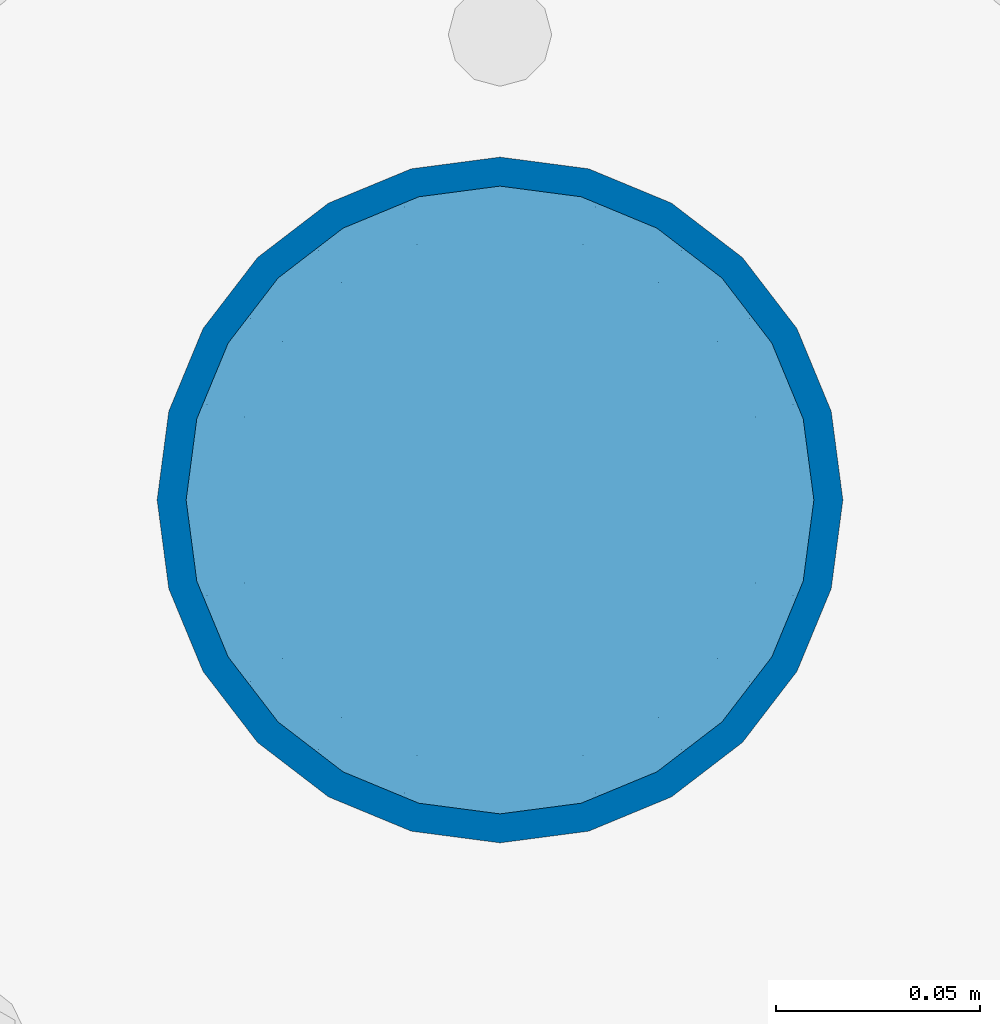
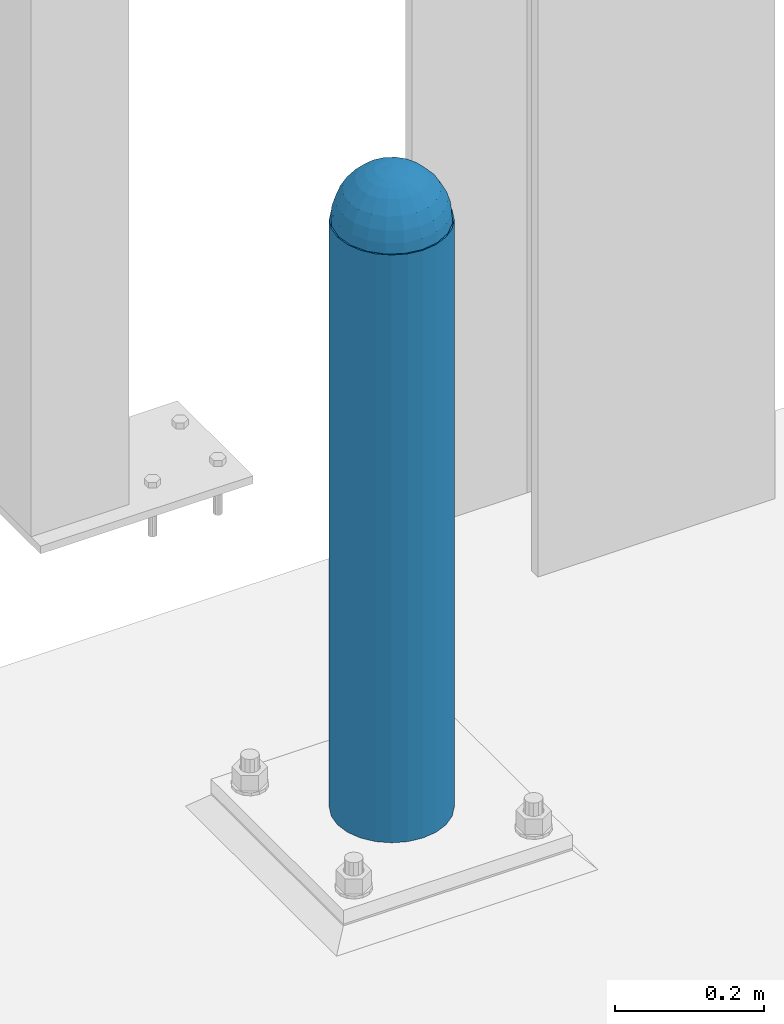
# One storey, part 1592 of 3843: 2 columns, 2 elements without a shape of their own.
"""IFC2X3 building model written with IfcOpenShell, lengths in millimetres."""

from ifc_helpers import new_model, si_unit, frame, origin_with_axes, place, context, subcontext, project, spatial, faceted_brep, material, type_object, element, aggregate, save


model = new_model("IFC2X3")

# Units and contexts
model_context = context("Model", 3, precision=1e-05, world=origin_with_axes())
body_context = subcontext(model_context, "Body", "Model", "MODEL_VIEW")
ifc_project = project(units=[si_unit("LENGTHUNIT", "METRE", prefix="MILLI"), si_unit("AREAUNIT", "SQUARE_METRE"), si_unit("VOLUMEUNIT", "CUBIC_METRE"), si_unit("MASSUNIT", "GRAM", prefix="KILO"), si_unit("TIMEUNIT", "SECOND"), si_unit("PLANEANGLEUNIT", "RADIAN"), si_unit("SOLIDANGLEUNIT", "STERADIAN"), si_unit("THERMODYNAMICTEMPERATUREUNIT", "DEGREE_CELSIUS"), si_unit("LUMINOUSINTENSITYUNIT", "LUMEN")], contexts=[model_context])

# Site, building, storey
site_placement = place(None, origin_with_axes())
site = spatial("IfcSite", under=ifc_project, at=site_placement, CompositionType="ELEMENT")
building_placement = place(site_placement, origin_with_axes())
building = spatial("IfcBuilding", under=site, at=building_placement, Name="Undefined", CompositionType="ELEMENT")
storey_placement = place(building_placement, origin_with_axes())
storey = spatial("IfcBuildingStorey", under=building, at=storey_placement, Name="Undefined", CompositionType="ELEMENT", Elevation=0.0)

# Assembly, column
assembly_1_placement = place(storey_placement, origin_with_axes())
assembly_1 = element("IfcElementAssembly", 1, at=assembly_1_placement, inside=storey, Name="CONC. FILL", AssemblyPlace="NOTDEFINED", PredefinedType="REINFORCEMENT_UNIT")
ifc_material_1 = material(Name="CONCRETE/1500")
column_type_1 = type_object("IfcColumnType", PredefinedType="NOTDEFINED")
column_1_placement = place(assembly_1_placement, frame((69596.0, 91605.1, 31411.8625), z_axis=(-1.0, 0.0, 0.0), x_axis=(0.0, 0.0, 1.0)))
column_1 = element("IfcColumn", 2, at=column_1_placement, type_object=column_type_1, material=ifc_material_1, Name="CONC. FILL", context=body_context, shape_type="Brep", body=[
    faceted_brep([(0.0, 0.0, 2.0), (0.0, -0.619999999995343, 1.89999999999964), (3.36549999999988, -7.1422259999963, 21.9814139999999), (3.36549999999988, 0.0, 23.1139999999996), (0.0, -1.17999999999302, 1.6200000000008), (3.36549999999988, -13.5910319999966, 18.6992260000006), (0.0, -1.61999999999534, 1.18000000000029), (3.36549999999988, -18.699225999997, 13.5910320000003), (0.0, -1.89999999999418, 0.6200000000008), (3.36549999999988, -21.9814139999944, 7.14222599999994), (0.0, -2.0, 0.0), (3.36549999999988, -23.1140000000014, 0.0), (0.0, -1.89999999999418, -0.6200000000008), (3.36549999999988, -21.9814139999944, -7.14222599999994), (0.0, -1.61999999999534, -1.18000000000029), (3.36549999999988, -18.699225999997, -13.5910320000003), (0.0, -1.17999999999302, -1.6200000000008), (3.36549999999988, -13.5910319999966, -18.6992260000006), (0.0, -0.619999999995343, -1.89999999999964), (3.36549999999988, -7.1422259999963, -21.9814139999999), (0.0, 0.0, -2.0), (3.36549999999988, 0.0, -23.1139999999996), (0.0, 0.619999999995343, -1.89999999999964), (3.36549999999988, 7.1422259999963, -21.9814139999999), (0.0, 1.17999999999302, -1.6200000000008), (3.36549999999988, 13.5910319999966, -18.6992260000006), (0.0, 1.61999999999534, -1.18000000000029), (3.36549999999988, 18.699225999997, -13.5910320000003), (0.0, 1.89999999999418, -0.6200000000008), (3.36549999999988, 21.9814139999944, -7.14222599999994), (0.0, 2.0, 0.0), (3.36549999999988, 23.1140000000014, 0.0), (0.0, 1.89999999999418, 0.6200000000008), (3.36549999999988, 21.9814139999944, 7.14222599999994), (0.0, 1.61999999999534, 1.18000000000029), (3.36549999999988, 18.699225999997, 13.5910320000003), (0.0, 1.17999999999302, 1.6200000000008), (3.36549999999988, 13.5910319999966, 18.6992260000006), (0.0, 0.619999999995343, 1.89999999999964), (3.36549999999988, 7.1422259999963, 21.9814139999999), (8.41374999999971, -11.1214661999984, 34.2282018000005), (8.41374999999971, 0.0, 35.9917999999998), (8.41374999999971, -21.1631784000056, 29.1173662000001), (8.41374999999971, -29.1173661999928, 21.1631784000001), (8.41374999999971, -34.2282017999969, 11.1214662000002), (8.41374999999971, -35.9918000000034, 0.0), (8.41374999999971, -34.2282017999969, -11.1214662000002), (8.41374999999971, -29.1173661999928, -21.1631784000001), (8.41374999999971, -21.1631784000056, -29.1173662000001), (8.41374999999971, -11.1214661999984, -34.2282018000005), (8.41374999999971, 0.0, -35.9917999999998), (8.41374999999971, 11.1214661999984, -34.2282018000005), (8.41374999999971, 21.1631784000056, -29.1173662000001), (8.41374999999971, 29.1173661999928, -21.1631784000001), (8.41374999999971, 34.2282017999969, -11.1214662000002), (8.41374999999971, 35.9918000000034, 0.0), (8.41374999999971, 34.2282017999969, 11.1214662000002), (8.41374999999971, 29.1173661999928, 21.1631784000001), (8.41374999999971, 21.1631784000056, 29.1173662000001), (8.41374999999971, 11.1214661999984, 34.2282018000005), (16.8274999999994, -15.3047700000025, 47.1030300000002), (16.8274999999994, 0.0, 49.5300000000007), (16.8274999999994, -29.1236400000053, 40.0697700000001), (16.8274999999994, -40.0697700000019, 29.1236399999998), (16.8274999999994, -47.1030299999984, 15.3047700000006), (16.8274999999994, -49.5299999999988, 0.0), (16.8274999999994, -47.1030299999984, -15.3047700000006), (16.8274999999994, -40.0697700000019, -29.1236399999998), (16.8274999999994, -29.1236400000053, -40.0697700000001), (16.8274999999994, -15.3047700000025, -47.1030300000002), (16.8274999999994, 0.0, -49.5300000000007), (16.8274999999994, 15.3047700000025, -47.1030300000002), (16.8274999999994, 29.1236400000053, -40.0697700000001), (16.8274999999994, 40.0697700000019, -29.1236399999998), (16.8274999999994, 47.1030299999984, -15.3047700000006), (16.8274999999994, 49.5299999999988, 0.0), (16.8274999999994, 47.1030299999984, 15.3047700000006), (16.8274999999994, 40.0697700000019, 29.1236399999998), (16.8274999999994, 29.1236400000053, 40.0697700000001), (16.8274999999994, 15.3047700000025, 47.1030300000002), (33.6549999999988, -20.4063599999936, 62.8040400000009), (33.6549999999988, 0.0, 66.0400000000009), (33.6549999999988, -38.831520000007, 53.4263599999995), (33.6549999999988, -53.4263599999977, 38.8315199999997), (33.6549999999988, -62.8040400000027, 20.4063600000009), (33.6549999999988, -66.0399999999936, 0.0), (33.6549999999988, -62.8040400000027, -20.4063600000009), (33.6549999999988, -53.4263599999977, -38.8315199999997), (33.6549999999988, -38.831520000007, -53.4263599999995), (33.6549999999988, -20.4063599999936, -62.8040400000009), (33.6549999999988, 0.0, -66.0400000000009), (33.6549999999988, 20.4063599999936, -62.8040400000009), (33.6549999999988, 38.831520000007, -53.4263599999995), (33.6549999999988, 53.4263599999977, -38.8315199999997), (33.6549999999988, 62.8040400000027, -20.4063600000009), (33.6549999999988, 66.0399999999936, 0.0), (33.6549999999988, 62.8040400000027, 20.4063600000009), (33.6549999999988, 53.4263599999977, 38.8315199999997), (33.6549999999988, 38.831520000007, 53.4263599999995), (33.6549999999988, 20.4063599999936, 62.8040400000009), (50.4824999999983, -23.3907901500061, 71.9891308499991), (50.4824999999983, 0.0, 75.6983500000006), (50.4824999999983, -44.5106298000028, 61.23996515), (50.4824999999983, -61.2399651500018, 44.5106297999992), (50.4824999999983, -71.9891308499937, 23.3907901500006), (50.4824999999983, -75.698350000006, 0.0), (50.4824999999983, -71.9891308499937, -23.3907901500006), (50.4824999999983, -61.2399651500018, -44.5106297999992), (50.4824999999983, -44.5106298000028, -61.23996515), (50.4824999999983, -23.3907901500061, -71.9891308499991), (50.4824999999983, 0.0, -75.6983500000006), (50.4824999999983, 23.3907901500061, -71.9891308499991), (50.4824999999983, 44.5106298000028, -61.23996515), (50.4824999999983, 61.2399651500018, -44.5106297999992), (50.4824999999983, 71.9891308499937, -23.3907901500006), (50.4824999999983, 75.698350000006, 0.0), (50.4824999999983, 71.9891308499937, 23.3907901500006), (50.4824999999983, 61.2399651500018, 44.5106297999992), (50.4824999999983, 44.5106298000028, 61.23996515), (50.4824999999983, 23.3907901500061, 71.9891308499991), (67.3099999999977, -24.9977910000016, 76.9349490000004), (67.3099999999977, 0.0, 80.8989999999994), (67.3099999999977, -47.5686120000028, 65.4472910000004), (67.3099999999977, -65.447291000004, 47.5686119999991), (67.3099999999977, -76.9349490000022, 24.9977909999998), (67.3099999999977, -80.8990000000049, 0.0), (67.3099999999977, -76.9349490000022, -24.9977909999998), (67.3099999999977, -65.447291000004, -47.5686119999991), (67.3099999999977, -47.5686120000028, -65.4472910000004), (67.3099999999977, -24.9977910000016, -76.9349490000004), (67.3099999999977, 0.0, -80.8989999999994), (67.3099999999977, 24.9977910000016, -76.9349490000004), (67.3099999999977, 47.5686120000028, -65.4472910000004), (67.3099999999977, 65.447291000004, -47.5686119999991), (67.3099999999977, 76.9349490000022, -24.9977909999998), (67.3099999999977, 80.8990000000049, 0.0), (67.3099999999977, 76.9349490000022, 24.9977909999998), (67.3099999999977, 65.447291000004, 47.5686119999991), (67.3099999999977, 47.5686120000028, 65.4472910000004), (67.3099999999977, 24.9977910000016, 76.9349490000004), (84.1374999999935, -25.5079499999993, 78.5050499999998), (84.1374999999935, 0.0, 82.5499999999993), (84.1374999999935, -48.5393999999942, 66.7829500000007), (84.1374999999935, -66.7829499999934, 48.5393999999997), (84.1374999999935, -78.505050000007, 25.5079499999993), (84.1374999999935, -82.5500000000029, 0.0), (84.1374999999935, -78.505050000007, -25.5079499999993), (84.1374999999935, -66.7829499999934, -48.5393999999997), (84.1374999999935, -48.5393999999942, -66.7829500000007), (84.1374999999935, -25.5079499999993, -78.5050499999998), (84.1374999999935, 0.0, -82.5499999999993), (84.1374999999935, 25.5079499999993, -78.5050499999998), (84.1374999999935, 48.5393999999942, -66.7829500000007), (84.1374999999935, 66.7829499999934, -48.5393999999997), (84.1374999999935, 78.505050000007, -25.5079499999993), (84.1374999999935, 82.5500000000029, 0.0), (84.1374999999935, 78.505050000007, 25.5079499999993), (84.1374999999935, 66.7829499999934, 48.5393999999997), (84.1374999999935, 48.5393999999942, 66.7829500000007), (84.1374999999935, 25.5079499999993, 78.5050499999998), (100.964999999993, -24.9977910000016, 76.9349490000004), (100.964999999993, 0.0, 80.8989999999994), (100.964999999993, -47.5686120000028, 65.4472910000004), (100.964999999993, -65.447291000004, 47.5686119999991), (100.964999999993, -76.9349490000022, 24.9977909999998), (100.964999999993, -80.8990000000049, 0.0), (100.964999999993, -76.9349490000022, -24.9977909999998), (100.964999999993, -65.447291000004, -47.5686119999991), (100.964999999993, -47.5686120000028, -65.4472910000004), (100.964999999993, -24.9977910000016, -76.9349490000004), (100.964999999993, 0.0, -80.8989999999994), (100.964999999993, 24.9977910000016, -76.9349490000004), (100.964999999993, 47.5686120000028, -65.4472910000004), (100.964999999993, 65.447291000004, -47.5686119999991), (100.964999999993, 76.9349490000022, -24.9977909999998), (100.964999999993, 80.8990000000049, 0.0), (100.964999999993, 76.9349490000022, 24.9977909999998), (100.964999999993, 65.447291000004, 47.5686119999991), (100.964999999993, 47.5686120000028, 65.4472910000004), (100.964999999993, 24.9977910000016, 76.9349490000004), (117.792499999992, -23.3907901500061, 71.9891308499991), (117.792499999992, 0.0, 75.6983500000006), (117.792499999992, -44.5106298000028, 61.23996515), (117.792499999992, -61.2399651500018, 44.5106297999992), (117.792499999992, -71.9891308499937, 23.3907901500006), (117.792499999992, -75.698350000006, 0.0), (117.792499999992, -71.9891308499937, -23.3907901500006), (117.792499999992, -61.2399651500018, -44.5106297999992), (117.792499999992, -44.5106298000028, -61.23996515), (117.792499999992, -23.3907901500061, -71.9891308499991), (117.792499999992, 0.0, -75.6983500000006), (117.792499999992, 23.3907901500061, -71.9891308499991), (117.792499999992, 44.5106298000028, -61.23996515), (117.792499999992, 61.2399651500018, -44.5106297999992), (117.792499999992, 71.9891308499937, -23.3907901500006), (117.792499999992, 75.698350000006, 0.0), (117.792499999992, 71.9891308499937, 23.3907901500006), (117.792499999992, 61.2399651500018, 44.5106297999992), (117.792499999992, 44.5106298000028, 61.23996515), (117.792499999992, 23.3907901500061, 71.9891308499991), (134.619999999992, -20.4063599999936, 62.8040400000009), (134.619999999992, 0.0, 66.0400000000009), (134.619999999992, -38.831520000007, 53.4263599999995), (134.619999999992, -53.4263599999977, 38.8315199999997), (134.619999999992, -62.8040400000027, 20.4063600000009), (134.619999999992, -66.0399999999936, 0.0), (134.619999999992, -62.8040400000027, -20.4063600000009), (134.619999999992, -53.4263599999977, -38.8315199999997), (134.619999999992, -38.831520000007, -53.4263599999995), (134.619999999992, -20.4063599999936, -62.8040400000009), (134.619999999992, 0.0, -66.0400000000009), (134.619999999992, 20.4063599999936, -62.8040400000009), (134.619999999992, 38.831520000007, -53.4263599999995), (134.619999999992, 53.4263599999977, -38.8315199999997), (134.619999999992, 62.8040400000027, -20.4063600000009), (134.619999999992, 66.0399999999936, 0.0), (134.619999999992, 62.8040400000027, 20.4063600000009), (134.619999999992, 53.4263599999977, 38.8315199999997), (134.619999999992, 38.831520000007, 53.4263599999995), (134.619999999992, 20.4063599999936, 62.8040400000009), (151.447499999991, -15.3047700000025, 47.1030300000002), (151.447499999991, 0.0, 49.5300000000007), (151.447499999991, -29.1236400000053, 40.0697700000001), (151.447499999991, -40.0697700000019, 29.1236399999998), (151.447499999991, -47.1030299999984, 15.3047700000006), (151.447499999991, -49.5299999999988, 0.0), (151.447499999991, -47.1030299999984, -15.3047700000006), (151.447499999991, -40.0697700000019, -29.1236399999998), (151.447499999991, -29.1236400000053, -40.0697700000001), (151.447499999991, -15.3047700000025, -47.1030300000002), (151.447499999991, 0.0, -49.5300000000007), (151.447499999991, 15.3047700000025, -47.1030300000002), (151.447499999991, 29.1236400000053, -40.0697700000001), (151.447499999991, 40.0697700000019, -29.1236399999998), (151.447499999991, 47.1030299999984, -15.3047700000006), (151.447499999991, 49.5299999999988, 0.0), (151.447499999991, 47.1030299999984, 15.3047700000006), (151.447499999991, 40.0697700000019, 29.1236399999998), (151.447499999991, 29.1236400000053, 40.0697700000001), (151.447499999991, 15.3047700000025, 47.1030300000002), (159.861249999991, -11.1214661999984, 34.2282018000005), (159.861249999991, 0.0, 35.9917999999998), (159.861249999991, -21.1631784000056, 29.1173662000001), (159.861249999991, -29.1173661999928, 21.1631784000001), (159.861249999991, -34.2282017999969, 11.1214662000002), (159.861249999991, -35.9918000000034, 0.0), (159.861249999991, -34.2282017999969, -11.1214662000002), (159.861249999991, -29.1173661999928, -21.1631784000001), (159.861249999991, -21.1631784000056, -29.1173662000001), (159.861249999991, -11.1214661999984, -34.2282018000005), (159.861249999991, 0.0, -35.9917999999998), (159.861249999991, 11.1214661999984, -34.2282018000005), (159.861249999991, 21.1631784000056, -29.1173662000001), (159.861249999991, 29.1173661999928, -21.1631784000001), (159.861249999991, 34.2282017999969, -11.1214662000002), (159.861249999991, 35.9918000000034, 0.0), (159.861249999991, 34.2282017999969, 11.1214662000002), (159.861249999991, 29.1173661999928, 21.1631784000001), (159.861249999991, 21.1631784000056, 29.1173662000001), (159.861249999991, 11.1214661999984, 34.2282018000005), (164.909499999991, -7.1422259999963, 21.9814139999999), (164.909499999991, 0.0, 23.1139999999996), (164.909499999991, -13.5910319999966, 18.6992260000006), (164.909499999991, -18.699225999997, 13.5910320000003), (164.909499999991, -21.9814139999944, 7.14222599999994), (164.909499999991, -23.1140000000014, 0.0), (164.909499999991, -21.9814139999944, -7.14222599999994), (164.909499999991, -18.699225999997, -13.5910320000003), (164.909499999991, -13.5910319999966, -18.6992260000006), (164.909499999991, -7.1422259999963, -21.9814139999999), (164.909499999991, 0.0, -23.1139999999996), (164.909499999991, 7.1422259999963, -21.9814139999999), (164.909499999991, 13.5910319999966, -18.6992260000006), (164.909499999991, 18.699225999997, -13.5910320000003), (164.909499999991, 21.9814139999944, -7.14222599999994), (164.909499999991, 23.1140000000014, 0.0), (164.909499999991, 21.9814139999944, 7.14222599999994), (164.909499999991, 18.699225999997, 13.5910320000003), (164.909499999991, 13.5910319999966, 18.6992260000006), (164.909499999991, 7.1422259999963, 21.9814139999999), (168.274999999991, -0.619999999995343, 1.89999999999964), (168.274999999991, 0.0, 2.0), (168.274999999991, -1.17999999999302, 1.6200000000008), (168.274999999991, -1.61999999999534, 1.18000000000029), (168.274999999991, -1.89999999999418, 0.6200000000008), (168.274999999991, -2.0, 0.0), (168.274999999991, -1.89999999999418, -0.6200000000008), (168.274999999991, -1.61999999999534, -1.18000000000029), (168.274999999991, -1.17999999999302, -1.6200000000008), (168.274999999991, -0.619999999995343, -1.89999999999964), (168.274999999991, 0.0, -2.0), (168.274999999991, 0.619999999995343, -1.89999999999964), (168.274999999991, 1.17999999999302, -1.6200000000008), (168.274999999991, 1.61999999999534, -1.18000000000029), (168.274999999991, 1.89999999999418, -0.6200000000008), (168.274999999991, 2.0, 0.0), (168.274999999991, 1.89999999999418, 0.6200000000008), (168.274999999991, 1.61999999999534, 1.18000000000029), (168.274999999991, 1.17999999999302, 1.6200000000008), (168.274999999991, 0.619999999995343, 1.89999999999964)], [[[0, 1, 2, 3]], [[1, 4, 5, 2]], [[4, 6, 7, 5]], [[6, 8, 9, 7]], [[8, 10, 11, 9]], [[10, 12, 13, 11]], [[12, 14, 15, 13]], [[14, 16, 17, 15]], [[16, 18, 19, 17]], [[18, 20, 21, 19]], [[20, 22, 23, 21]], [[22, 24, 25, 23]], [[24, 26, 27, 25]], [[26, 28, 29, 27]], [[28, 30, 31, 29]], [[30, 32, 33, 31]], [[32, 34, 35, 33]], [[34, 36, 37, 35]], [[36, 38, 39, 37]], [[38, 0, 3, 39]], [[38, 36, 34, 32, 30, 28, 26, 24, 22, 20, 18, 16, 14, 12, 10, 8, 6, 4, 1, 0]], [[3, 2, 40, 41]], [[2, 5, 42, 40]], [[5, 7, 43, 42]], [[7, 9, 44, 43]], [[9, 11, 45, 44]], [[11, 13, 46, 45]], [[13, 15, 47, 46]], [[15, 17, 48, 47]], [[17, 19, 49, 48]], [[19, 21, 50, 49]], [[21, 23, 51, 50]], [[23, 25, 52, 51]], [[25, 27, 53, 52]], [[27, 29, 54, 53]], [[29, 31, 55, 54]], [[31, 33, 56, 55]], [[33, 35, 57, 56]], [[35, 37, 58, 57]], [[37, 39, 59, 58]], [[39, 3, 41, 59]], [[41, 40, 60, 61]], [[40, 42, 62, 60]], [[42, 43, 63, 62]], [[43, 44, 64, 63]], [[44, 45, 65, 64]], [[45, 46, 66, 65]], [[46, 47, 67, 66]], [[47, 48, 68, 67]], [[48, 49, 69, 68]], [[49, 50, 70, 69]], [[50, 51, 71, 70]], [[51, 52, 72, 71]], [[52, 53, 73, 72]], [[53, 54, 74, 73]], [[54, 55, 75, 74]], [[55, 56, 76, 75]], [[56, 57, 77, 76]], [[57, 58, 78, 77]], [[58, 59, 79, 78]], [[59, 41, 61, 79]], [[61, 60, 80, 81]], [[60, 62, 82, 80]], [[62, 63, 83, 82]], [[63, 64, 84, 83]], [[64, 65, 85, 84]], [[65, 66, 86, 85]], [[66, 67, 87, 86]], [[67, 68, 88, 87]], [[68, 69, 89, 88]], [[69, 70, 90, 89]], [[70, 71, 91, 90]], [[71, 72, 92, 91]], [[72, 73, 93, 92]], [[73, 74, 94, 93]], [[74, 75, 95, 94]], [[75, 76, 96, 95]], [[76, 77, 97, 96]], [[77, 78, 98, 97]], [[78, 79, 99, 98]], [[79, 61, 81, 99]], [[81, 80, 100, 101]], [[80, 82, 102, 100]], [[82, 83, 103, 102]], [[83, 84, 104, 103]], [[84, 85, 105, 104]], [[85, 86, 106, 105]], [[86, 87, 107, 106]], [[87, 88, 108, 107]], [[88, 89, 109, 108]], [[89, 90, 110, 109]], [[90, 91, 111, 110]], [[91, 92, 112, 111]], [[92, 93, 113, 112]], [[93, 94, 114, 113]], [[94, 95, 115, 114]], [[95, 96, 116, 115]], [[96, 97, 117, 116]], [[97, 98, 118, 117]], [[98, 99, 119, 118]], [[99, 81, 101, 119]], [[101, 100, 120, 121]], [[100, 102, 122, 120]], [[102, 103, 123, 122]], [[103, 104, 124, 123]], [[104, 105, 125, 124]], [[105, 106, 126, 125]], [[106, 107, 127, 126]], [[107, 108, 128, 127]], [[108, 109, 129, 128]], [[109, 110, 130, 129]], [[110, 111, 131, 130]], [[111, 112, 132, 131]], [[112, 113, 133, 132]], [[113, 114, 134, 133]], [[114, 115, 135, 134]], [[115, 116, 136, 135]], [[116, 117, 137, 136]], [[117, 118, 138, 137]], [[118, 119, 139, 138]], [[119, 101, 121, 139]], [[121, 120, 140, 141]], [[120, 122, 142, 140]], [[122, 123, 143, 142]], [[123, 124, 144, 143]], [[124, 125, 145, 144]], [[125, 126, 146, 145]], [[126, 127, 147, 146]], [[127, 128, 148, 147]], [[128, 129, 149, 148]], [[129, 130, 150, 149]], [[130, 131, 151, 150]], [[131, 132, 152, 151]], [[132, 133, 153, 152]], [[133, 134, 154, 153]], [[134, 135, 155, 154]], [[135, 136, 156, 155]], [[136, 137, 157, 156]], [[137, 138, 158, 157]], [[138, 139, 159, 158]], [[139, 121, 141, 159]], [[141, 140, 160, 161]], [[140, 142, 162, 160]], [[142, 143, 163, 162]], [[143, 144, 164, 163]], [[144, 145, 165, 164]], [[145, 146, 166, 165]], [[146, 147, 167, 166]], [[147, 148, 168, 167]], [[148, 149, 169, 168]], [[149, 150, 170, 169]], [[150, 151, 171, 170]], [[151, 152, 172, 171]], [[152, 153, 173, 172]], [[153, 154, 174, 173]], [[154, 155, 175, 174]], [[155, 156, 176, 175]], [[156, 157, 177, 176]], [[157, 158, 178, 177]], [[158, 159, 179, 178]], [[159, 141, 161, 179]], [[161, 160, 180, 181]], [[160, 162, 182, 180]], [[162, 163, 183, 182]], [[163, 164, 184, 183]], [[164, 165, 185, 184]], [[165, 166, 186, 185]], [[166, 167, 187, 186]], [[167, 168, 188, 187]], [[168, 169, 189, 188]], [[169, 170, 190, 189]], [[170, 171, 191, 190]], [[171, 172, 192, 191]], [[172, 173, 193, 192]], [[173, 174, 194, 193]], [[174, 175, 195, 194]], [[175, 176, 196, 195]], [[176, 177, 197, 196]], [[177, 178, 198, 197]], [[178, 179, 199, 198]], [[179, 161, 181, 199]], [[181, 180, 200, 201]], [[180, 182, 202, 200]], [[182, 183, 203, 202]], [[183, 184, 204, 203]], [[184, 185, 205, 204]], [[185, 186, 206, 205]], [[186, 187, 207, 206]], [[187, 188, 208, 207]], [[188, 189, 209, 208]], [[189, 190, 210, 209]], [[190, 191, 211, 210]], [[191, 192, 212, 211]], [[192, 193, 213, 212]], [[193, 194, 214, 213]], [[194, 195, 215, 214]], [[195, 196, 216, 215]], [[196, 197, 217, 216]], [[197, 198, 218, 217]], [[198, 199, 219, 218]], [[199, 181, 201, 219]], [[201, 200, 220, 221]], [[200, 202, 222, 220]], [[202, 203, 223, 222]], [[203, 204, 224, 223]], [[204, 205, 225, 224]], [[205, 206, 226, 225]], [[206, 207, 227, 226]], [[207, 208, 228, 227]], [[208, 209, 229, 228]], [[209, 210, 230, 229]], [[210, 211, 231, 230]], [[211, 212, 232, 231]], [[212, 213, 233, 232]], [[213, 214, 234, 233]], [[214, 215, 235, 234]], [[215, 216, 236, 235]], [[216, 217, 237, 236]], [[217, 218, 238, 237]], [[218, 219, 239, 238]], [[219, 201, 221, 239]], [[221, 220, 240, 241]], [[220, 222, 242, 240]], [[222, 223, 243, 242]], [[223, 224, 244, 243]], [[224, 225, 245, 244]], [[225, 226, 246, 245]], [[226, 227, 247, 246]], [[227, 228, 248, 247]], [[228, 229, 249, 248]], [[229, 230, 250, 249]], [[230, 231, 251, 250]], [[231, 232, 252, 251]], [[232, 233, 253, 252]], [[233, 234, 254, 253]], [[234, 235, 255, 254]], [[235, 236, 256, 255]], [[236, 237, 257, 256]], [[237, 238, 258, 257]], [[238, 239, 259, 258]], [[239, 221, 241, 259]], [[241, 240, 260, 261]], [[240, 242, 262, 260]], [[242, 243, 263, 262]], [[243, 244, 264, 263]], [[244, 245, 265, 264]], [[245, 246, 266, 265]], [[246, 247, 267, 266]], [[247, 248, 268, 267]], [[248, 249, 269, 268]], [[249, 250, 270, 269]], [[250, 251, 271, 270]], [[251, 252, 272, 271]], [[252, 253, 273, 272]], [[253, 254, 274, 273]], [[254, 255, 275, 274]], [[255, 256, 276, 275]], [[256, 257, 277, 276]], [[257, 258, 278, 277]], [[258, 259, 279, 278]], [[259, 241, 261, 279]], [[261, 260, 280, 281]], [[260, 262, 282, 280]], [[262, 263, 283, 282]], [[263, 264, 284, 283]], [[264, 265, 285, 284]], [[265, 266, 286, 285]], [[266, 267, 287, 286]], [[267, 268, 288, 287]], [[268, 269, 289, 288]], [[269, 270, 290, 289]], [[270, 271, 291, 290]], [[271, 272, 292, 291]], [[272, 273, 293, 292]], [[273, 274, 294, 293]], [[274, 275, 295, 294]], [[275, 276, 296, 295]], [[276, 277, 297, 296]], [[277, 278, 298, 297]], [[278, 279, 299, 298]], [[279, 261, 281, 299]], [[282, 283, 284, 285, 286, 287, 288, 289, 290, 291, 292, 293, 294, 295, 296, 297, 298, 299, 281, 280]]]),
])
aggregate(assembly_1, [column_1])

assembly_2_placement = place(storey_placement, origin_with_axes())
assembly_2 = element("IfcElementAssembly", 3, at=assembly_2_placement, inside=storey, Name="PIPE_BOLLARD", AssemblyPlace="NOTDEFINED", PredefinedType="RIGID_FRAME")
ifc_material_2 = material()
column_type_2 = type_object("IfcColumnType", Name="PIPE6SCH40", PredefinedType="NOTDEFINED")
column_2_placement = place(assembly_2_placement, frame((69596.0, 91605.1, 30480.0), z_axis=(-1.0, 0.0, 0.0), x_axis=(0.0, 0.0, 1.0)))
column_2 = element("IfcColumn", 4, at=column_2_placement, type_object=column_type_2, material=ifc_material_2, Name="PIPE_BOLLARD", ObjectType="PIPE6SCH40", context=body_context, shape_type="Brep", body=[
    faceted_brep([(50.7999999999993, -77.0890000000072, 0.0), (50.7999999999993, -74.4622560228017, 19.9521013679114), (1016.0, -74.4622560228017, 19.9521013679114), (1016.0, -77.0890000000072, 0.0), (50.7999999999993, -66.7610323523404, 38.5445000000036), (1016.0, -66.7610323523404, 38.5445000000036), (50.7999999999993, -54.5101546548831, 54.5101546548904), (1016.0, -54.5101546548831, 54.5101546548904), (50.7999999999993, -38.5445000000036, 66.7610323523404), (1016.0, -38.5445000000036, 66.7610323523404), (50.7999999999993, -19.9521013679041, 74.4622560227945), (1016.0, -19.9521013679041, 74.4622560227945), (50.7999999999993, 0.0, 77.0889999999999), (1016.0, 0.0, 77.0889999999999), (50.7999999999993, 19.9521013679041, 74.4622560227945), (1016.0, 19.9521013679041, 74.4622560227945), (50.7999999999993, 38.5445000000036, 66.7610323523404), (1016.0, 38.5445000000036, 66.7610323523404), (50.7999999999993, 54.5101546548831, 54.5101546548904), (1016.0, 54.5101546548831, 54.5101546548904), (50.7999999999993, 66.7610323523404, 38.5445000000036), (1016.0, 66.7610323523404, 38.5445000000036), (50.7999999999993, 74.4622560228017, 19.9521013679114), (1016.0, 74.4622560228017, 19.9521013679114), (50.7999999999993, 77.0890000000072, 0.0), (1016.0, 77.0890000000072, 0.0), (50.7999999999993, 74.4622560228017, -19.9521013679114), (1016.0, 74.4622560228017, -19.9521013679114), (50.7999999999993, 66.7610323523404, -38.5445000000036), (1016.0, 66.7610323523404, -38.5445000000036), (50.7999999999993, 54.5101546548831, -54.5101546548904), (1016.0, 54.5101546548831, -54.5101546548904), (50.7999999999993, 38.5445000000036, -66.7610323523404), (1016.0, 38.5445000000036, -66.7610323523404), (50.7999999999993, 19.9521013679041, -74.4622560227945), (1016.0, 19.9521013679041, -74.4622560227945), (50.7999999999993, 0.0, -77.0889999999999), (1016.0, 0.0, -77.0889999999999), (50.7999999999993, -19.9521013679041, -74.4622560227945), (1016.0, -19.9521013679041, -74.4622560227945), (50.7999999999993, -38.5445000000036, -66.7610323523404), (1016.0, -38.5445000000036, -66.7610323523404), (50.7999999999993, -54.5101546548831, -54.5101546548904), (1016.0, -54.5101546548831, -54.5101546548904), (50.7999999999993, -66.7610323523404, -38.5445000000036), (1016.0, -66.7610323523404, -38.5445000000036), (50.7999999999993, -74.4622560228017, -19.9521013679114), (1016.0, -74.4622560228017, -19.9521013679114), (50.7999999999993, -84.2010000000009, 0.0), (50.7999999999993, -81.3319204993604, -21.7928224166753), (1016.0, -81.3319204993604, -21.7928224166753), (1016.0, -84.2010000000009, 0.0), (50.7999999999993, -72.9202050240565, -42.1005000000005), (1016.0, -72.9202050240565, -42.1005000000005), (50.7999999999993, -59.5390980826924, -59.5390980826851), (1016.0, -59.5390980826924, -59.5390980826851), (50.7999999999993, -42.1005000000005, -72.9202050240565), (1016.0, -42.1005000000005, -72.9202050240565), (50.7999999999993, -21.7928224166826, -81.3319204993677), (1016.0, -21.7928224166826, -81.3319204993677), (50.7999999999993, 0.0, -84.2010000000009), (1016.0, 0.0, -84.2010000000009), (50.7999999999993, 21.7928224166826, -81.3319204993677), (1016.0, 21.7928224166826, -81.3319204993677), (50.7999999999993, 42.1005000000005, -72.9202050240565), (1016.0, 42.1005000000005, -72.9202050240565), (50.7999999999993, 59.5390980826924, -59.5390980826851), (1016.0, 59.5390980826924, -59.5390980826851), (50.7999999999993, 72.9202050240565, -42.1005000000005), (1016.0, 72.9202050240565, -42.1005000000005), (50.7999999999993, 81.3319204993604, -21.7928224166753), (1016.0, 81.3319204993604, -21.7928224166753), (50.7999999999993, 84.2010000000009, 0.0), (1016.0, 84.2010000000009, 0.0), (50.7999999999993, 81.3319204993604, 21.7928224166753), (1016.0, 81.3319204993604, 21.7928224166753), (50.7999999999993, 72.9202050240565, 42.1005000000005), (1016.0, 72.9202050240565, 42.1005000000005), (50.7999999999993, 59.5390980826924, 59.5390980826851), (1016.0, 59.5390980826924, 59.5390980826851), (50.7999999999993, 42.1005000000005, 72.9202050240565), (1016.0, 42.1005000000005, 72.9202050240565), (50.7999999999993, 21.7928224166826, 81.3319204993677), (1016.0, 21.7928224166826, 81.3319204993677), (50.7999999999993, 0.0, 84.2010000000009), (1016.0, 0.0, 84.2010000000009), (50.7999999999993, -21.7928224166826, 81.3319204993677), (1016.0, -21.7928224166826, 81.3319204993677), (50.7999999999993, -42.1005000000005, 72.9202050240565), (1016.0, -42.1005000000005, 72.9202050240565), (50.7999999999993, -59.5390980826924, 59.5390980826851), (1016.0, -59.5390980826924, 59.5390980826851), (50.7999999999993, -72.9202050240565, 42.1005000000005), (1016.0, -72.9202050240565, 42.1005000000005), (50.7999999999993, -81.3319204993604, 21.7928224166753), (1016.0, -81.3319204993604, 21.7928224166753)], [[[0, 1, 2, 3]], [[1, 4, 5, 2]], [[4, 6, 7, 5]], [[6, 8, 9, 7]], [[8, 10, 11, 9]], [[10, 12, 13, 11]], [[12, 14, 15, 13]], [[14, 16, 17, 15]], [[16, 18, 19, 17]], [[18, 20, 21, 19]], [[20, 22, 23, 21]], [[22, 24, 25, 23]], [[24, 26, 27, 25]], [[26, 28, 29, 27]], [[28, 30, 31, 29]], [[30, 32, 33, 31]], [[32, 34, 35, 33]], [[34, 36, 37, 35]], [[36, 38, 39, 37]], [[38, 40, 41, 39]], [[40, 42, 43, 41]], [[42, 44, 45, 43]], [[44, 46, 47, 45]], [[46, 0, 3, 47]], [[48, 49, 50, 51]], [[49, 52, 53, 50]], [[52, 54, 55, 53]], [[54, 56, 57, 55]], [[56, 58, 59, 57]], [[58, 60, 61, 59]], [[60, 62, 63, 61]], [[62, 64, 65, 63]], [[64, 66, 67, 65]], [[66, 68, 69, 67]], [[68, 70, 71, 69]], [[70, 72, 73, 71]], [[72, 74, 75, 73]], [[74, 76, 77, 75]], [[76, 78, 79, 77]], [[78, 80, 81, 79]], [[80, 82, 83, 81]], [[82, 84, 85, 83]], [[84, 86, 87, 85]], [[86, 88, 89, 87]], [[88, 90, 91, 89]], [[90, 92, 93, 91]], [[92, 94, 95, 93]], [[94, 48, 51, 95]], [[53, 55, 57, 59, 61, 63, 65, 67, 69, 71, 73, 75, 77, 79, 81, 83, 85, 87, 89, 91, 93, 95, 51, 50], [5, 7, 9, 11, 13, 15, 17, 19, 21, 23, 25, 27, 29, 31, 33, 35, 37, 39, 41, 43, 45, 47, 3, 2]], [[94, 92, 90, 88, 86, 84, 82, 80, 78, 76, 74, 72, 70, 68, 66, 64, 62, 60, 58, 56, 54, 52, 49, 48], [46, 44, 42, 40, 38, 36, 34, 32, 30, 28, 26, 24, 22, 20, 18, 16, 14, 12, 10, 8, 6, 4, 1, 0]]]),
])
aggregate(assembly_2, [column_2])

save(model, "model.ifc")
